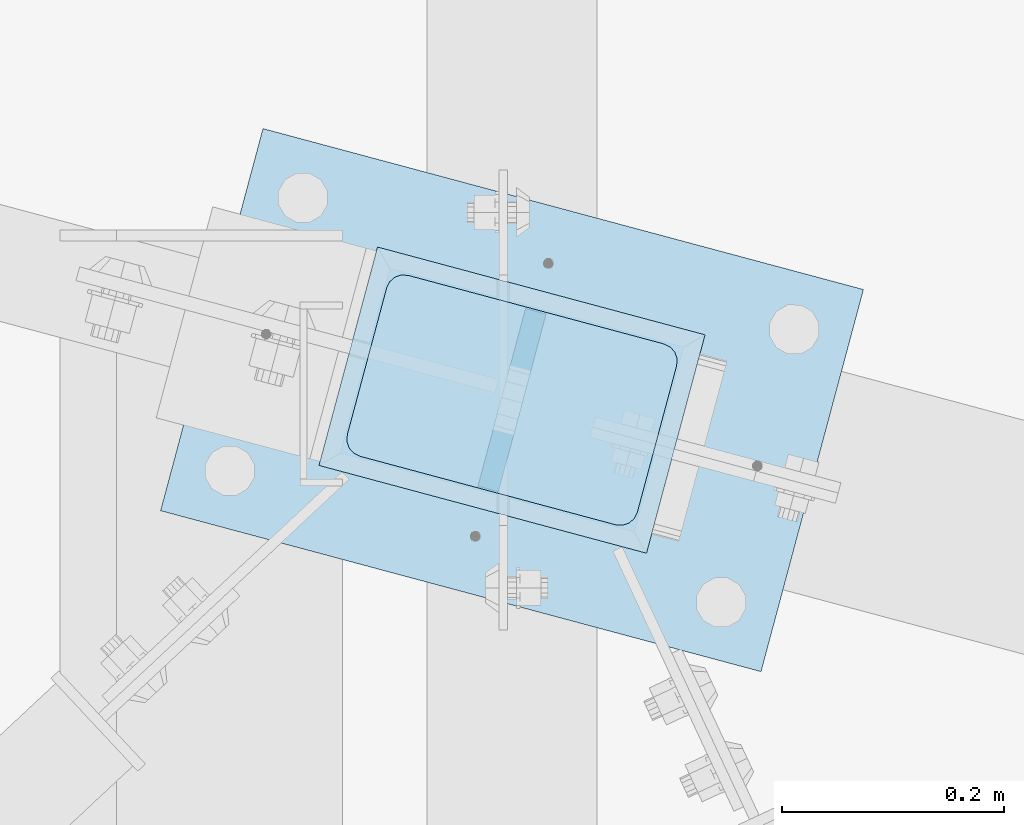
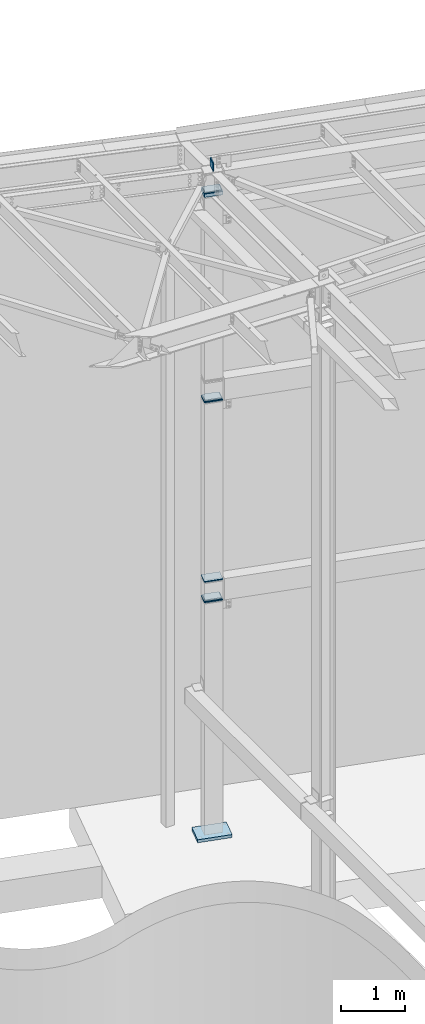
# One storey, part 1665 of 1763: 13 plates, 1 element without a shape of its own.
"""IFC2X3 building model written with IfcOpenShell, lengths in millimetres."""

import ifcopenshell
import ifcopenshell.guid

model = None  # the IFC model being written
_history = None  # IfcOwnerHistory: only IFC2X3 demands one
_inside = {}  # id of a spatial element -> (the spatial element, [elements in it])
_under = {}  # id of a project, library or spatial element -> (it, [spatial elements below it])
_declared = {}  # id of a project -> (the project, [libraries it declares])
_typed = {}  # id of a type object -> (the type object, [elements of that type])
_made_of = {}  # id of a material, layer set ... -> (it, [elements and type objects made of it])


def new_model(schema):
    """Start an empty IFC model of exactly this schema.

    Asked for "IFC4X3", IfcOpenShell would pick the latest addendum, in which some entities
    have other attributes; the version numbers below select the first issue.
    IFC2X3 requires an IfcOwnerHistory on every rooted entity: one is made here for all.
    """
    global model, _history
    if schema == "IFC4X3":
        model = ifcopenshell.file(schema_version=(4, 3, 0, 0))
    else:
        model = ifcopenshell.file(schema=schema)
    _inside.clear()
    _under.clear()
    _declared.clear()
    _typed.clear()
    _made_of.clear()
    _history = None
    if model.schema == "IFC2X3":
        org = make("IfcOrganization", Name="unknown")
        user = make(
            "IfcPersonAndOrganization",
            ThePerson=make("IfcPerson", FamilyName="unknown"),
            TheOrganization=org,
        )
        app = make(
            "IfcApplication",
            ApplicationDeveloper=org,
            Version="unknown",
            ApplicationFullName="unknown",
            ApplicationIdentifier="unknown",
        )
        _history = make(
            "IfcOwnerHistory",
            OwningUser=user,
            OwningApplication=app,
            ChangeAction="ADDED",
            CreationDate=0,
        )
    return model


def make(cls, **values):
    """One entity of the class cls with the attributes given. An attribute that is None is left unset."""
    return model.create_entity(
        cls, **{name: value for name, value in values.items() if value is not None}
    )


def rooted(cls, **values):
    """An entity with a GlobalId (a new one), such as an element, a storey or a relation."""
    return make(cls, GlobalId=ifcopenshell.guid.new(), OwnerHistory=_history, **values)


def si_unit(unit_type, name, prefix=None):
    """IfcSIUnit, for example si_unit("LENGTHUNIT", "METRE", prefix="MILLI")."""
    return make("IfcSIUnit", UnitType=unit_type, Prefix=prefix, Name=name)


def assignment(units):
    """IfcUnitAssignment: the units of a project."""
    return None if units is None else make("IfcUnitAssignment", Units=units)


def point(xyz):
    """IfcCartesianPoint."""
    return None if xyz is None else make("IfcCartesianPoint", Coordinates=xyz)


def direction(xyz):
    """IfcDirection."""
    return None if xyz is None else make("IfcDirection", DirectionRatios=xyz)


def frame(location, z_axis=None, x_axis=None):
    """IfcAxis2Placement3D, a coordinate frame: its origin and axes. An axis left out is left unset."""
    return make(
        "IfcAxis2Placement3D",
        Location=point(location),
        Axis=direction(z_axis),
        RefDirection=direction(x_axis),
    )


def origin_with_axes():
    """The frame at (0, 0, 0) with the z axis (0, 0, 1) and the x axis (1, 0, 0) written out."""
    return frame((0.0, 0.0, 0.0), z_axis=(0.0, 0.0, 1.0), x_axis=(1.0, 0.0, 0.0))


def place(relative_to, where):
    """IfcLocalPlacement: puts the frame where relative to a parent placement (None: the world)."""
    return make(
        "IfcLocalPlacement", PlacementRelTo=relative_to, RelativePlacement=where
    )


def context(
    kind, dimensions, precision=None, world=None, true_north=None, identifier=None
):
    """IfcGeometricRepresentationContext, for example the 3D "Model" context."""
    return make(
        "IfcGeometricRepresentationContext",
        ContextIdentifier=identifier,
        ContextType=kind,
        CoordinateSpaceDimension=dimensions,
        Precision=precision,
        WorldCoordinateSystem=world,
        TrueNorth=true_north,
    )


def subcontext(parent, identifier, kind, view, scale=None):
    """IfcGeometricRepresentationSubContext, for example "Body" below "Model"."""
    return make(
        "IfcGeometricRepresentationSubContext",
        ContextIdentifier=identifier,
        ContextType=kind,
        ParentContext=parent,
        TargetScale=scale,
        TargetView=view,
    )


def project(units=None, contexts=None):
    """IfcProject with its units and contexts."""
    return rooted(
        "IfcProject",
        Name="project",
        RepresentationContexts=contexts,
        UnitsInContext=assignment(units),
    )


def spatial(cls, under=None, at=None, **own):
    """A site, building, storey or space (cls), placed at a placement, below another one or the project."""
    s = rooted(cls, ObjectPlacement=at, **own)
    if under is not None:
        _under.setdefault(under.id(), (under, []))[1].append(s)
    return s


def faces_of(points, faces, orient=None, outer=None):
    """IfcFace entities. A face is a list of loops; a loop is a list of indices into points, from 0.

    orient and outer hold one flag for each loop. By default every Orientation is true, the
    first loop of a face is its IfcFaceOuterBound and the others are IfcFaceBound.
    """
    made = []
    for i, loops in enumerate(faces):
        bounds = []
        for j, loop in enumerate(loops):
            is_outer = j == 0 if outer is None else outer[i][j]
            bounds.append(
                make(
                    "IfcFaceOuterBound" if is_outer else "IfcFaceBound",
                    Bound=make("IfcPolyLoop", Polygon=[points[k] for k in loop]),
                    Orientation=True if orient is None else orient[i][j],
                )
            )
        made.append(make("IfcFace", Bounds=bounds))
    return made


def faceted_brep(points, faces, orient=None, outer=None, voids=None):
    """IfcFacetedBrep: a solid bounded by flat faces; with voids (closed shells), ...WithVoids."""
    shared = [point(p) for p in points]
    hull = make("IfcClosedShell", CfsFaces=faces_of(shared, faces, orient, outer))
    if voids is None:
        return make("IfcFacetedBrep", Outer=hull)
    return make(
        "IfcFacetedBrepWithVoids",
        Outer=hull,
        Voids=[
            make(cls, CfsFaces=faces_of(shared, fs, o, b)) for cls, fs, o, b in voids
        ],
    )


def shape(context_of_items, identifier, shape_type, items):
    """IfcShapeRepresentation: the items that make up one representation, for example the "Body"."""
    return make(
        "IfcShapeRepresentation",
        ContextOfItems=context_of_items,
        RepresentationIdentifier=identifier,
        RepresentationType=shape_type,
        Items=items,
    )


def material(Name=None, Category=None):
    """IfcMaterial."""
    return make("IfcMaterial", Name=Name, Category=Category)


def made_of(thing, what):
    """Note that an element or type object is made of a material, layer set ...; save() writes the relation."""
    if what is not None:
        _made_of.setdefault(what.id(), (what, []))[1].append(thing)
    return thing


def type_object(cls, material=None, **own):
    """A type object (cls), such as IfcWallType, which elements share."""
    return made_of(rooted(cls, **own), material)


def element(
    cls,
    number,
    at=None,
    inside=None,
    cuts=None,
    type_object=None,
    material=None,
    context=None,
    identifier="Body",
    shape_type=None,
    held_by="IfcProductDefinitionShape",
    body=None,
    shapes=None,
    **own,
):
    """One element of the class cls, such as IfcWall. Its Tag is "e" and its number.

    at: its placement. inside: the storey or other place that contains it. cuts: it is an
    opening in that element (IfcRelVoidsElement). A single representation is given by context,
    identifier, shape_type and body (its items); several are given by shapes. held_by: the class
    of the entity that holds the representations. save() writes the other relations.
    """
    e = rooted(cls, Tag="e%d" % number, ObjectPlacement=at, **own)
    if body is not None:
        shapes = [shape(context, identifier, shape_type, body)]
    if shapes is not None:
        e.Representation = make(held_by, Representations=shapes)
    if inside is not None:
        _inside.setdefault(inside.id(), (inside, []))[1].append(e)
    if cuts is not None:
        rooted(
            "IfcRelVoidsElement", RelatingBuildingElement=cuts, RelatedOpeningElement=e
        )
    if type_object is not None:
        _typed.setdefault(type_object.id(), (type_object, []))[1].append(e)
    return made_of(e, material)


def aggregate(whole, parts):
    """IfcRelAggregates: a whole, such as a stair, and the parts it consists of."""
    return rooted("IfcRelAggregates", RelatingObject=whole, RelatedObjects=parts)


def save(model, path):
    """Write the relations noted so far, then the file.

    IfcRelAggregates (storeys below a building ...), IfcRelContainedInSpatialStructure (elements
    in a storey), IfcRelDefinesByType, IfcRelAssociatesMaterial and IfcRelDeclares: one each for
    every whole, place, type object, material and project.
    """
    for whole, parts in _under.values():
        aggregate(whole, parts)
    for where, things in _inside.values():
        rooted(
            "IfcRelContainedInSpatialStructure",
            RelatedElements=things,
            RelatingStructure=where,
        )
    for kind, things in _typed.values():
        rooted("IfcRelDefinesByType", RelatedObjects=things, RelatingType=kind)
    for what, things in _made_of.values():
        rooted("IfcRelAssociatesMaterial", RelatedObjects=things, RelatingMaterial=what)
    for by, libraries in _declared.values():
        rooted("IfcRelDeclares", RelatingContext=by, RelatedDefinitions=libraries)
    model.write(path)


model = new_model("IFC2X3")

# Units and contexts
model_context = context("Model", 3, precision=1e-05, world=origin_with_axes())
body_context = subcontext(model_context, "Body", "Model", "MODEL_VIEW")
ifc_project = project(units=[si_unit("LENGTHUNIT", "METRE", prefix="MILLI"), si_unit("AREAUNIT", "SQUARE_METRE"), si_unit("VOLUMEUNIT", "CUBIC_METRE"), si_unit("MASSUNIT", "GRAM", prefix="KILO"), si_unit("TIMEUNIT", "SECOND"), si_unit("PLANEANGLEUNIT", "RADIAN"), si_unit("SOLIDANGLEUNIT", "STERADIAN"), si_unit("THERMODYNAMICTEMPERATUREUNIT", "DEGREE_CELSIUS"), si_unit("LUMINOUSINTENSITYUNIT", "LUMEN")], contexts=[model_context])

# Site, building, storey
site_placement = place(None, origin_with_axes())
site = spatial("IfcSite", under=ifc_project, at=site_placement, CompositionType="ELEMENT")
building_placement = place(site_placement, origin_with_axes())
building = spatial("IfcBuilding", under=site, at=building_placement, Name="Undefined", CompositionType="ELEMENT")
storey_placement = place(building_placement, origin_with_axes())
storey = spatial("IfcBuildingStorey", under=building, at=storey_placement, Name="Undefined", CompositionType="ELEMENT", Elevation=0.0)

# Assembly, plates
assembly_placement = place(storey_placement, origin_with_axes())
assembly = element("IfcElementAssembly", 1, at=assembly_placement, inside=storey, Name="COLUMN", AssemblyPlace="NOTDEFINED", PredefinedType="RIGID_FRAME")
ifc_material_1 = material(Name="STEEL/A36")
plate_type_1 = type_object("IfcPlateType", PredefinedType="NOTDEFINED")
plate_1_placement = place(assembly_placement, frame((-39780.8567256757, 66797.60536682, 8105.775), z_axis=(0.965913267114843, -0.258865912030785, 0.0), x_axis=(-0.258865912030778, -0.965913267114844, 3.00823476209188e-08)))
plate_1 = element("IfcPlate", 2, at=plate_1_placement, type_object=plate_type_1, material=ifc_material_1, Name="PLATE", context=body_context, shape_type="Brep", body=[
    faceted_brep([(-2.18278728425503e-11, -12.7000000000007, 15.875), (-1.67347025126219e-10, -12.7000000000007, 253.999999999985), (-1.67347025126219e-10, 12.7000000000007, 253.999999999985), (-2.18278728425503e-11, 12.7000000000007, 15.875), (1.20841242121242, -12.7000000000007, 260.075099488779), (1.20841242121242, 12.7000000000007, 260.075099488779), (4.649679848495, -12.7000000000007, 265.225320151323), (4.649679848495, 12.7000000000007, 265.225320151323), (9.79990051103232, -12.7000000000007, 268.666587578606), (9.79990051103232, 12.7000000000007, 268.666587578606), (15.8749999998181, -12.7000000000007, 269.874999999993), (15.8749999998181, 12.7000000000007, 269.874999999993), (152.400009155084, -12.7000000000007, 269.875000000073), (152.400009155084, 12.7000000000007, 269.875000000073), (158.475108643877, -12.7000000000007, 268.6665875787), (158.475108643877, 12.7000000000007, 268.6665875787), (163.625329306422, -12.7000000000007, 265.225320151425), (163.625329306422, 12.7000000000007, 265.225320151425), (167.066596733705, -12.7000000000007, 260.07509948888), (167.066596733705, 12.7000000000007, 260.07509948888), (168.275009155092, -12.7000000000007, 254.000000000087), (168.275009155092, 12.7000000000007, 254.000000000087), (168.275009155237, -12.7000000000007, 15.8750000001019), (168.275009155237, 12.7000000000007, 15.8750000001019), (167.066596733865, -12.7000000000007, 9.79990051130881), (167.066596733865, 12.7000000000007, 9.79990051130881), (163.625329306582, -12.7000000000007, 4.64967984876421), (163.625329306582, 12.7000000000007, 4.64967984876421), (158.475108644045, -12.7000000000007, 1.20841242148163), (158.475108644045, 12.7000000000007, 1.20841242148163), (152.400000000001, -12.6999998092651, 0.0), (152.400000000001, 12.6999998092651, 0.0), (15.8749999999854, -12.7000000000007, 0.0), (15.8749999999854, 12.7000000000007, 0.0), (9.79990051119239, -12.7000000000007, 1.20841242137976), (9.79990051119239, 12.7000000000007, 1.20841242137976), (4.64967984864779, -12.7000000000007, 4.64967984866234), (4.64967984864779, 12.7000000000007, 4.64967984866234), (1.20841242136521, -12.7000000000007, 9.79990051119967), (1.20841242136521, 12.7000000000007, 9.79990051119967)], [[[0, 1, 2, 3]], [[1, 4, 5, 2]], [[4, 6, 7, 5]], [[6, 8, 9, 7]], [[8, 10, 11, 9]], [[10, 12, 13, 11]], [[12, 14, 15, 13]], [[14, 16, 17, 15]], [[16, 18, 19, 17]], [[18, 20, 21, 19]], [[20, 22, 23, 21]], [[22, 24, 25, 23]], [[24, 26, 27, 25]], [[26, 28, 29, 27]], [[28, 30, 31, 29]], [[30, 32, 33, 31]], [[32, 34, 35, 33]], [[34, 36, 37, 35]], [[36, 38, 39, 37]], [[38, 0, 3, 39]], [[5, 7, 9, 11, 13, 15, 17, 19, 21, 23, 25, 27, 29, 31, 33, 35, 37, 39, 3, 2]], [[38, 36, 34, 32, 30, 28, 26, 24, 22, 20, 18, 16, 14, 12, 10, 8, 6, 4, 1, 0]]]),
])
plate_2_placement = place(assembly_placement, frame((-39780.856725713, 66797.60536683, 8064.5), z_axis=(0.965913267114843, -0.258865912030785, 0.0), x_axis=(-0.258865912030778, -0.965913267114844, 3.00823476209188e-08)))
plate_2 = element("IfcPlate", 3, at=plate_2_placement, type_object=plate_type_1, material=ifc_material_1, Name="PLATE", context=body_context, shape_type="Brep", body=[
    faceted_brep([(-2.18278728425503e-11, -12.7000000000007, 15.875), (-1.67347025126219e-10, -12.7000000000007, 253.999999999985), (-1.67347025126219e-10, 12.7000000000007, 253.999999999985), (-2.18278728425503e-11, 12.7000000000007, 15.875), (1.20841242121242, -12.7000000000007, 260.075099488779), (1.20841242121242, 12.7000000000007, 260.075099488779), (4.649679848495, -12.7000000000007, 265.225320151323), (4.649679848495, 12.7000000000007, 265.225320151323), (9.79990051103232, -12.7000000000007, 268.666587578606), (9.79990051103232, 12.7000000000007, 268.666587578606), (15.8749999998181, -12.7000000000007, 269.874999999993), (15.8749999998181, 12.7000000000007, 269.874999999993), (152.400009155084, -12.7000000000007, 269.875000000073), (152.400009155084, 12.7000000000007, 269.875000000073), (158.475108643877, -12.7000000000007, 268.6665875787), (158.475108643877, 12.7000000000007, 268.6665875787), (163.625329306422, -12.7000000000007, 265.225320151425), (163.625329306422, 12.7000000000007, 265.225320151425), (167.066596733705, -12.7000000000007, 260.07509948888), (167.066596733705, 12.7000000000007, 260.07509948888), (168.275009155092, -12.7000000000007, 254.000000000087), (168.275009155092, 12.7000000000007, 254.000000000087), (168.275009155237, -12.7000000000007, 15.8750000001019), (168.275009155237, 12.7000000000007, 15.8750000001019), (167.066596733865, -12.7000000000007, 9.79990051130881), (167.066596733865, 12.7000000000007, 9.79990051130881), (163.625329306582, -12.7000000000007, 4.64967984876421), (163.625329306582, 12.7000000000007, 4.64967984876421), (158.475108644045, -12.7000000000007, 1.20841242148163), (158.475108644045, 12.7000000000007, 1.20841242148163), (152.400000000001, -12.6999998092651, 0.0), (152.400000000001, 12.6999998092651, 0.0), (15.8749999999854, -12.7000000000007, 0.0), (15.8749999999854, 12.7000000000007, 0.0), (9.79990051119239, -12.7000000000007, 1.20841242137976), (9.79990051119239, 12.7000000000007, 1.20841242137976), (4.64967984864779, -12.7000000000007, 4.64967984866234), (4.64967984864779, 12.7000000000007, 4.64967984866234), (1.20841242136521, -12.7000000000007, 9.79990051119967), (1.20841242136521, 12.7000000000007, 9.79990051119967)], [[[0, 1, 2, 3]], [[1, 4, 5, 2]], [[4, 6, 7, 5]], [[6, 8, 9, 7]], [[8, 10, 11, 9]], [[10, 12, 13, 11]], [[12, 14, 15, 13]], [[14, 16, 17, 15]], [[16, 18, 19, 17]], [[18, 20, 21, 19]], [[20, 22, 23, 21]], [[22, 24, 25, 23]], [[24, 26, 27, 25]], [[26, 28, 29, 27]], [[28, 30, 31, 29]], [[30, 32, 33, 31]], [[32, 34, 35, 33]], [[34, 36, 37, 35]], [[36, 38, 39, 37]], [[38, 0, 3, 39]], [[5, 7, 9, 11, 13, 15, 17, 19, 21, 23, 25, 27, 29, 31, 33, 35, 37, 39, 3, 2]], [[38, 36, 34, 32, 30, 28, 26, 24, 22, 20, 18, 16, 14, 12, 10, 8, 6, 4, 1, 0]]]),
])
plate_3_placement = place(assembly_placement, frame((-39780.8472022852, 66797.6028150352, 4645.025), z_axis=(0.965913267114843, -0.258865912030785, 0.0), x_axis=(-0.258865912030778, -0.965913267114844, 3.00823476209188e-08)))
plate_3 = element("IfcPlate", 4, at=plate_3_placement, type_object=plate_type_1, material=ifc_material_1, Name="PLATE", context=body_context, shape_type="Brep", body=[
    faceted_brep([(-2.18278728425503e-11, -12.7000000000007, 15.875), (-1.67347025126219e-10, -12.7000000000007, 253.999999999985), (-1.67347025126219e-10, 12.7000000000007, 253.999999999985), (-2.18278728425503e-11, 12.7000000000007, 15.875), (1.20841242121242, -12.7000000000007, 260.075099488779), (1.20841242121242, 12.7000000000007, 260.075099488779), (4.649679848495, -12.7000000000007, 265.225320151323), (4.649679848495, 12.7000000000007, 265.225320151323), (9.79990051103232, -12.7000000000007, 268.666587578606), (9.79990051103232, 12.7000000000007, 268.666587578606), (15.8749999998181, -12.7000000000007, 269.874999999993), (15.8749999998181, 12.7000000000007, 269.874999999993), (152.400009155084, -12.7000000000007, 269.875000000073), (152.400009155084, 12.7000000000007, 269.875000000073), (158.475108643877, -12.7000000000007, 268.6665875787), (158.475108643877, 12.7000000000007, 268.6665875787), (163.625329306422, -12.7000000000007, 265.225320151425), (163.625329306422, 12.7000000000007, 265.225320151425), (167.066596733705, -12.7000000000007, 260.07509948888), (167.066596733705, 12.7000000000007, 260.07509948888), (168.275009155092, -12.7000000000007, 254.000000000087), (168.275009155092, 12.7000000000007, 254.000000000087), (168.275009155237, -12.7000000000007, 15.8750000001019), (168.275009155237, 12.7000000000007, 15.8750000001019), (167.066596733865, -12.7000000000007, 9.79990051130881), (167.066596733865, 12.7000000000007, 9.79990051130881), (163.625329306582, -12.7000000000007, 4.64967984876421), (163.625329306582, 12.7000000000007, 4.64967984876421), (158.475108644045, -12.7000000000007, 1.20841242148163), (158.475108644045, 12.7000000000007, 1.20841242148163), (152.400000000001, -12.6999998092651, 0.0), (152.400000000001, 12.6999998092651, 0.0), (15.8749999999854, -12.7000000000007, 0.0), (15.8749999999854, 12.7000000000007, 0.0), (9.79990051119239, -12.7000000000007, 1.20841242137976), (9.79990051119239, 12.7000000000007, 1.20841242137976), (4.64967984864779, -12.7000000000007, 4.64967984866234), (4.64967984864779, 12.7000000000007, 4.64967984866234), (1.20841242136521, -12.7000000000007, 9.79990051119967), (1.20841242136521, 12.7000000000007, 9.79990051119967)], [[[0, 1, 2, 3]], [[1, 4, 5, 2]], [[4, 6, 7, 5]], [[6, 8, 9, 7]], [[8, 10, 11, 9]], [[10, 12, 13, 11]], [[12, 14, 15, 13]], [[14, 16, 17, 15]], [[16, 18, 19, 17]], [[18, 20, 21, 19]], [[20, 22, 23, 21]], [[22, 24, 25, 23]], [[24, 26, 27, 25]], [[26, 28, 29, 27]], [[28, 30, 31, 29]], [[30, 32, 33, 31]], [[32, 34, 35, 33]], [[34, 36, 37, 35]], [[36, 38, 39, 37]], [[38, 0, 3, 39]], [[5, 7, 9, 11, 13, 15, 17, 19, 21, 23, 25, 27, 29, 31, 33, 35, 37, 39, 3, 2]], [[38, 36, 34, 32, 30, 28, 26, 24, 22, 20, 18, 16, 14, 12, 10, 8, 6, 4, 1, 0]]]),
])
plate_4_placement = place(assembly_placement, frame((-39780.8472022484, 66797.6028150254, 4295.775), z_axis=(0.965913267114843, -0.258865912030785, 0.0), x_axis=(-0.258865912030778, -0.965913267114844, 3.00823476209188e-08)))
plate_4 = element("IfcPlate", 5, at=plate_4_placement, type_object=plate_type_1, material=ifc_material_1, Name="PLATE", context=body_context, shape_type="Brep", body=[
    faceted_brep([(-2.18278728425503e-11, -12.7000000000007, 15.875), (-1.67347025126219e-10, -12.7000000000007, 253.999999999985), (-1.67347025126219e-10, 12.7000000000007, 253.999999999985), (-2.18278728425503e-11, 12.7000000000007, 15.875), (1.20841242121242, -12.7000000000007, 260.075099488779), (1.20841242121242, 12.7000000000007, 260.075099488779), (4.649679848495, -12.7000000000007, 265.225320151323), (4.649679848495, 12.7000000000007, 265.225320151323), (9.79990051103232, -12.7000000000007, 268.666587578606), (9.79990051103232, 12.7000000000007, 268.666587578606), (15.8749999998181, -12.7000000000007, 269.874999999993), (15.8749999998181, 12.7000000000007, 269.874999999993), (152.400009155084, -12.7000000000007, 269.875000000073), (152.400009155084, 12.7000000000007, 269.875000000073), (158.475108643877, -12.7000000000007, 268.6665875787), (158.475108643877, 12.7000000000007, 268.6665875787), (163.625329306422, -12.7000000000007, 265.225320151425), (163.625329306422, 12.7000000000007, 265.225320151425), (167.066596733705, -12.7000000000007, 260.07509948888), (167.066596733705, 12.7000000000007, 260.07509948888), (168.275009155092, -12.7000000000007, 254.000000000087), (168.275009155092, 12.7000000000007, 254.000000000087), (168.275009155237, -12.7000000000007, 15.8750000001019), (168.275009155237, 12.7000000000007, 15.8750000001019), (167.066596733865, -12.7000000000007, 9.79990051130881), (167.066596733865, 12.7000000000007, 9.79990051130881), (163.625329306582, -12.7000000000007, 4.64967984876421), (163.625329306582, 12.7000000000007, 4.64967984876421), (158.475108644045, -12.7000000000007, 1.20841242148163), (158.475108644045, 12.7000000000007, 1.20841242148163), (152.400000000001, -12.6999998092651, 0.0), (152.400000000001, 12.6999998092651, 0.0), (15.8749999999854, -12.7000000000007, 0.0), (15.8749999999854, 12.7000000000007, 0.0), (9.79990051119239, -12.7000000000007, 1.20841242137976), (9.79990051119239, 12.7000000000007, 1.20841242137976), (4.64967984864779, -12.7000000000007, 4.64967984866234), (4.64967984864779, 12.7000000000007, 4.64967984866234), (1.20841242136521, -12.7000000000007, 9.79990051119967), (1.20841242136521, 12.7000000000007, 9.79990051119967)], [[[0, 1, 2, 3]], [[1, 4, 5, 2]], [[4, 6, 7, 5]], [[6, 8, 9, 7]], [[8, 10, 11, 9]], [[10, 12, 13, 11]], [[12, 14, 15, 13]], [[14, 16, 17, 15]], [[16, 18, 19, 17]], [[18, 20, 21, 19]], [[20, 22, 23, 21]], [[22, 24, 25, 23]], [[24, 26, 27, 25]], [[26, 28, 29, 27]], [[28, 30, 31, 29]], [[30, 32, 33, 31]], [[32, 34, 35, 33]], [[34, 36, 37, 35]], [[36, 38, 39, 37]], [[38, 0, 3, 39]], [[5, 7, 9, 11, 13, 15, 17, 19, 21, 23, 25, 27, 29, 31, 33, 35, 37, 39, 3, 2]], [[38, 36, 34, 32, 30, 28, 26, 24, 22, 20, 18, 16, 14, 12, 10, 8, 6, 4, 1, 0]]]),
])
plate_5_placement = place(assembly_placement, frame((-39780.8472022858, 66797.6028150354, 4254.5), z_axis=(0.965913267114843, -0.258865912030785, 0.0), x_axis=(-0.258865912030778, -0.965913267114844, 3.00823476209188e-08)))
plate_5 = element("IfcPlate", 6, at=plate_5_placement, type_object=plate_type_1, material=ifc_material_1, Name="PLATE", context=body_context, shape_type="Brep", body=[
    faceted_brep([(-2.18278728425503e-11, -12.7000000000007, 15.875), (-1.67347025126219e-10, -12.7000000000007, 253.999999999985), (-1.67347025126219e-10, 12.7000000000007, 253.999999999985), (-2.18278728425503e-11, 12.7000000000007, 15.875), (1.20841242121242, -12.7000000000007, 260.075099488779), (1.20841242121242, 12.7000000000007, 260.075099488779), (4.649679848495, -12.7000000000007, 265.225320151323), (4.649679848495, 12.7000000000007, 265.225320151323), (9.79990051103232, -12.7000000000007, 268.666587578606), (9.79990051103232, 12.7000000000007, 268.666587578606), (15.8749999998181, -12.7000000000007, 269.874999999993), (15.8749999998181, 12.7000000000007, 269.874999999993), (152.400009155084, -12.7000000000007, 269.875000000073), (152.400009155084, 12.7000000000007, 269.875000000073), (158.475108643877, -12.7000000000007, 268.6665875787), (158.475108643877, 12.7000000000007, 268.6665875787), (163.625329306422, -12.7000000000007, 265.225320151425), (163.625329306422, 12.7000000000007, 265.225320151425), (167.066596733705, -12.7000000000007, 260.07509948888), (167.066596733705, 12.7000000000007, 260.07509948888), (168.275009155092, -12.7000000000007, 254.000000000087), (168.275009155092, 12.7000000000007, 254.000000000087), (168.275009155237, -12.7000000000007, 15.8750000001019), (168.275009155237, 12.7000000000007, 15.8750000001019), (167.066596733865, -12.7000000000007, 9.79990051130881), (167.066596733865, 12.7000000000007, 9.79990051130881), (163.625329306582, -12.7000000000007, 4.64967984876421), (163.625329306582, 12.7000000000007, 4.64967984876421), (158.475108644045, -12.7000000000007, 1.20841242148163), (158.475108644045, 12.7000000000007, 1.20841242148163), (152.400000000001, -12.6999998092651, 0.0), (152.400000000001, 12.6999998092651, 0.0), (15.8749999999854, -12.7000000000007, 0.0), (15.8749999999854, 12.7000000000007, 0.0), (9.79990051119239, -12.7000000000007, 1.20841242137976), (9.79990051119239, 12.7000000000007, 1.20841242137976), (4.64967984864779, -12.7000000000007, 4.64967984866234), (4.64967984864779, 12.7000000000007, 4.64967984866234), (1.20841242136521, -12.7000000000007, 9.79990051119967), (1.20841242136521, 12.7000000000007, 9.79990051119967)], [[[0, 1, 2, 3]], [[1, 4, 5, 2]], [[4, 6, 7, 5]], [[6, 8, 9, 7]], [[8, 10, 11, 9]], [[10, 12, 13, 11]], [[12, 14, 15, 13]], [[14, 16, 17, 15]], [[16, 18, 19, 17]], [[18, 20, 21, 19]], [[20, 22, 23, 21]], [[22, 24, 25, 23]], [[24, 26, 27, 25]], [[26, 28, 29, 27]], [[28, 30, 31, 29]], [[30, 32, 33, 31]], [[32, 34, 35, 33]], [[34, 36, 37, 35]], [[36, 38, 39, 37]], [[38, 0, 3, 39]], [[5, 7, 9, 11, 13, 15, 17, 19, 21, 23, 25, 27, 29, 31, 33, 35, 37, 39, 3, 2]], [[38, 36, 34, 32, 30, 28, 26, 24, 22, 20, 18, 16, 14, 12, 10, 8, 6, 4, 1, 0]]]),
])
plate_type_2 = type_object("IfcPlateType", PredefinedType="NOTDEFINED")
plate_6_placement = place(assembly_placement, frame((-39780.8472031509, 66797.602812108, 11985.625), z_axis=(0.965913267114843, -0.258865912030785, 0.0), x_axis=(-0.258865912030778, -0.965913267114844, 3.00823476209188e-08)))
plate_6 = element("IfcPlate", 7, at=plate_6_placement, type_object=plate_type_2, material=ifc_material_1, Name="PLATE", context=body_context, shape_type="Brep", body=[
    faceted_brep([(7.27595761418343e-11, -9.52499999999964, 15.8750000001601), (1.13504938781261e-09, -9.52499999999964, 254.000000000065), (1.13504938781261e-09, 9.52499999999964, 254.000000000065), (7.27595761418343e-11, 9.52499999999964, 15.8750000001601), (1.20841242253664, -9.52499999999964, 260.075099488837), (1.20841242253664, 9.52499999999964, 260.075099488837), (4.64967984981922, -9.52499999999964, 265.225320151352), (4.64967984981922, 9.52499999999964, 265.225320151352), (9.79990051234927, -9.52499999999964, 268.666587578613), (9.79990051234927, 9.52499999999964, 268.666587578613), (15.8750000011278, -9.52499999999964, 269.874999999993), (15.8750000011278, 9.52499999999964, 269.874999999993), (152.400009155099, -9.52499999999964, 269.87500000008), (152.400009155099, 9.52499999999964, 269.87500000008), (158.475108643885, -9.52499999999964, 268.6665875787), (158.475108643885, 9.52499999999964, 268.6665875787), (163.625329306429, -9.52499999999964, 265.225320151425), (163.625329306429, 9.52499999999964, 265.225320151425), (167.066596733726, -9.52499999999964, 260.07509948888), (167.066596733726, 9.52499999999964, 260.07509948888), (168.275009155106, -9.52499999999964, 254.000000000087), (168.275009155106, 9.52499999999964, 254.000000000087), (168.275009155259, -9.52499999999964, 15.8750000008658), (168.275009155259, 9.52499999999964, 15.8750000008658), (167.066596733886, -9.52499999999964, 9.79990051209461), (167.066596733886, 9.52499999999964, 9.79990051209461), (163.625329306633, -9.52499999999964, 4.64967984955729), (163.625329306633, 9.52499999999964, 4.64967984955729), (158.475108644117, -9.52499999999964, 1.20841242226743), (158.475108644117, 9.52499999999964, 1.20841242226743), (152.400009155353, -9.52499999999964, 8.58562998473644e-10), (152.400009155353, 9.52499999999964, 8.58562998473644e-10), (15.8750000001673, -9.52499999999964, 8.73114913702011e-11), (15.8750000001673, 9.52499999999964, 8.73114913702011e-11), (9.79990051132336, -9.52499999999964, 1.20841242144525), (9.79990051132336, 9.52499999999964, 1.20841242144525), (4.64967984874238, -9.52499999999964, 4.64967984874238), (4.64967984874238, 9.52499999999964, 4.64967984874238), (1.20841242144525, -9.52499999999964, 9.79990051132336), (1.20841242144525, 9.52499999999964, 9.79990051132336)], [[[0, 1, 2, 3]], [[1, 4, 5, 2]], [[4, 6, 7, 5]], [[6, 8, 9, 7]], [[8, 10, 11, 9]], [[10, 12, 13, 11]], [[12, 14, 15, 13]], [[14, 16, 17, 15]], [[16, 18, 19, 17]], [[18, 20, 21, 19]], [[20, 22, 23, 21]], [[22, 24, 25, 23]], [[24, 26, 27, 25]], [[26, 28, 29, 27]], [[28, 30, 31, 29]], [[30, 32, 33, 31]], [[32, 34, 35, 33]], [[34, 36, 37, 35]], [[36, 38, 39, 37]], [[38, 0, 3, 39]], [[5, 7, 9, 11, 13, 15, 17, 19, 21, 23, 25, 27, 29, 31, 33, 35, 37, 39, 3, 2]], [[38, 36, 34, 32, 30, 28, 26, 24, 22, 20, 18, 16, 14, 12, 10, 8, 6, 4, 1, 0]]]),
])
plate_7_placement = place(assembly_placement, frame((-39780.8472031329, 66797.602812104, 12068.175), z_axis=(0.965913267114843, -0.258865912030785, 0.0), x_axis=(-0.258865912030778, -0.965913267114844, 3.00823476209188e-08)))
plate_7 = element("IfcPlate", 8, at=plate_7_placement, type_object=plate_type_2, material=ifc_material_1, Name="PLATE", context=body_context, shape_type="Brep", body=[
    faceted_brep([(7.27595761418343e-11, -9.52499999999964, 15.8750000001601), (1.13504938781261e-09, -9.52499999999964, 254.000000000065), (1.13504938781261e-09, 9.52499999999964, 254.000000000065), (7.27595761418343e-11, 9.52499999999964, 15.8750000001601), (1.20841242253664, -9.52499999999964, 260.075099488837), (1.20841242253664, 9.52499999999964, 260.075099488837), (4.64967984981922, -9.52499999999964, 265.225320151352), (4.64967984981922, 9.52499999999964, 265.225320151352), (9.79990051234927, -9.52499999999964, 268.666587578613), (9.79990051234927, 9.52499999999964, 268.666587578613), (15.8750000011278, -9.52499999999964, 269.874999999993), (15.8750000011278, 9.52499999999964, 269.874999999993), (152.400009155099, -9.52499999999964, 269.87500000008), (152.400009155099, 9.52499999999964, 269.87500000008), (158.475108643885, -9.52499999999964, 268.6665875787), (158.475108643885, 9.52499999999964, 268.6665875787), (163.625329306429, -9.52499999999964, 265.225320151425), (163.625329306429, 9.52499999999964, 265.225320151425), (167.066596733726, -9.52499999999964, 260.07509948888), (167.066596733726, 9.52499999999964, 260.07509948888), (168.275009155106, -9.52499999999964, 254.000000000087), (168.275009155106, 9.52499999999964, 254.000000000087), (168.275009155259, -9.52499999999964, 15.8750000008658), (168.275009155259, 9.52499999999964, 15.8750000008658), (167.066596733886, -9.52499999999964, 9.79990051209461), (167.066596733886, 9.52499999999964, 9.79990051209461), (163.625329306633, -9.52499999999964, 4.64967984955729), (163.625329306633, 9.52499999999964, 4.64967984955729), (158.475108644117, -9.52499999999964, 1.20841242226743), (158.475108644117, 9.52499999999964, 1.20841242226743), (152.400009155353, -9.52499999999964, 8.58562998473644e-10), (152.400009155353, 9.52499999999964, 8.58562998473644e-10), (15.8750000001673, -9.52499999999964, 8.73114913702011e-11), (15.8750000001673, 9.52499999999964, 8.73114913702011e-11), (9.79990051132336, -9.52499999999964, 1.20841242144525), (9.79990051132336, 9.52499999999964, 1.20841242144525), (4.64967984874238, -9.52499999999964, 4.64967984874238), (4.64967984874238, 9.52499999999964, 4.64967984874238), (1.20841242144525, -9.52499999999964, 9.79990051132336), (1.20841242144525, 9.52499999999964, 9.79990051132336)], [[[0, 1, 2, 3]], [[1, 4, 5, 2]], [[4, 6, 7, 5]], [[6, 8, 9, 7]], [[8, 10, 11, 9]], [[10, 12, 13, 11]], [[12, 14, 15, 13]], [[14, 16, 17, 15]], [[16, 18, 19, 17]], [[18, 20, 21, 19]], [[20, 22, 23, 21]], [[22, 24, 25, 23]], [[24, 26, 27, 25]], [[26, 28, 29, 27]], [[28, 30, 31, 29]], [[30, 32, 33, 31]], [[32, 34, 35, 33]], [[34, 36, 37, 35]], [[36, 38, 39, 37]], [[38, 0, 3, 39]], [[5, 7, 9, 11, 13, 15, 17, 19, 21, 23, 25, 27, 29, 31, 33, 35, 37, 39, 3, 2]], [[38, 36, 34, 32, 30, 28, 26, 24, 22, 20, 18, 16, 14, 12, 10, 8, 6, 4, 1, 0]]]),
])
ifc_material_2 = material(Name="STEEL/A572-50")
plate_type_3 = type_object("IfcPlateType", PredefinedType="NOTDEFINED")
plate_8_placement = place(assembly_placement, frame((-39793.1940109033, 66818.9905198919, 8085.1375), z_axis=(0.965913267114843, -0.258865912030785, 0.0), x_axis=(-0.258865912030778, -0.965913267114844, 3.00823476209188e-08)))
plate_8 = element("IfcPlate", 9, at=plate_8_placement, type_object=plate_type_3, material=ifc_material_2, Name="PLATE", context=body_context, shape_type="Brep", body=[
    faceted_brep([(-7.27595761418343e-12, -7.9375, 0.0), (-1.96450855582952e-10, -7.9375, 304.799987792954), (-1.96450855582952e-10, 7.9375, 304.799987792954), (-7.27595761418343e-12, 7.9375, 0.0), (203.199996948031, -7.9375, 304.799987793078), (203.199996948031, 7.9375, 304.799987793078), (203.199996948228, -7.9375, 1.30967237055302e-10), (203.199996948228, 7.9375, 1.30967237055302e-10)], [[[0, 1, 2, 3]], [[1, 4, 5, 2]], [[4, 6, 7, 5]], [[6, 0, 3, 7]], [[5, 7, 3, 2]], [[6, 4, 1, 0]]]),
])
plate_9_placement = place(assembly_placement, frame((-39793.1844874755, 66818.9879680971, 4665.6625), z_axis=(0.965913267114843, -0.258865912030785, 0.0), x_axis=(-0.258865912030778, -0.965913267114844, 3.00823476209188e-08)))
plate_9 = element("IfcPlate", 10, at=plate_9_placement, type_object=plate_type_3, material=ifc_material_2, Name="PLATE", context=body_context, shape_type="Brep", body=[
    faceted_brep([(-7.27595761418343e-12, -7.9375, 0.0), (-1.96450855582952e-10, -7.9375, 304.799987792954), (-1.96450855582952e-10, 7.9375, 304.799987792954), (-7.27595761418343e-12, 7.9375, 0.0), (203.199996948031, -7.9375, 304.799987793078), (203.199996948031, 7.9375, 304.799987793078), (203.199996948228, -7.9375, 1.30967237055302e-10), (203.199996948228, 7.9375, 1.30967237055302e-10)], [[[0, 1, 2, 3]], [[1, 4, 5, 2]], [[4, 6, 7, 5]], [[6, 0, 3, 7]], [[5, 7, 3, 2]], [[6, 4, 1, 0]]]),
])
plate_10_placement = place(assembly_placement, frame((-39793.1844874761, 66818.9879680972, 4275.1375), z_axis=(0.965913267114843, -0.258865912030785, 0.0), x_axis=(-0.258865912030778, -0.965913267114844, 3.00823476209188e-08)))
plate_10 = element("IfcPlate", 11, at=plate_10_placement, type_object=plate_type_3, material=ifc_material_2, Name="PLATE", context=body_context, shape_type="Brep", body=[
    faceted_brep([(-7.27595761418343e-12, -7.9375, 0.0), (-1.96450855582952e-10, -7.9375, 304.799987792954), (-1.96450855582952e-10, 7.9375, 304.799987792954), (-7.27595761418343e-12, 7.9375, 0.0), (203.199996948031, -7.9375, 304.799987793078), (203.199996948031, 7.9375, 304.799987793078), (203.199996948228, -7.9375, 1.30967237055302e-10), (203.199996948228, 7.9375, 1.30967237055302e-10)], [[[0, 1, 2, 3]], [[1, 4, 5, 2]], [[4, 6, 7, 5]], [[6, 0, 3, 7]], [[5, 7, 3, 2]], [[6, 4, 1, 0]]]),
])
plate_type_4 = type_object("IfcPlateType", PredefinedType="NOTDEFINED")
plate_11_placement = place(assembly_placement, frame((-39650.8921786426, 66761.2289433038, 12611.0999938965), z_axis=(0.0, 0.0, -1.0), x_axis=(-0.258911937048181, -0.965900931179776, 0.0)))
plate_11 = element("IfcPlate", 12, at=plate_11_placement, type_object=plate_type_4, material=ifc_material_2, Name="PLATE", context=body_context, shape_type="Brep", body=[
    faceted_brep([(7.27595761418343e-12, 9.52500000000146, 155.574990844727), (-1.45519152283669e-11, 7.27595761418343e-12, 165.099990844727), (165.288833618244, 2.18278728425503e-10, 165.099990844727), (165.288833618273, 9.52500000021973, 155.574990844727), (-3.63797880709171e-11, -9.5249999999869, 155.574990844727), (165.288833618222, -9.5249999997759, 155.574990844727), (0.0, 9.52500000000146, 0.0), (0.0, -9.52500000000146, 0.0), (165.288833618222, -9.5249999997759, 0.0), (165.288833618273, 9.52500000021973, 0.0)], [[[0, 1, 2, 3]], [[1, 4, 5, 2]], [[6, 7, 4, 1, 0]], [[5, 8, 9, 3, 2]], [[8, 7, 6, 9]], [[9, 6, 0, 3]], [[7, 8, 5, 4]]]),
])
plate_type_5 = type_object("IfcPlateType", PredefinedType="NOTDEFINED")
plate_12_placement = place(assembly_placement, frame((-39793.194023473, 66818.9905201003, 12026.9), z_axis=(0.965913267114843, -0.258865912030785, 0.0), x_axis=(-0.258865912030778, -0.965913267114844, 3.00823476209188e-08)))
plate_12 = element("IfcPlate", 13, at=plate_12_placement, type_object=plate_type_5, material=ifc_material_2, Name="PLATE", context=body_context, shape_type="Brep", body=[
    faceted_brep([(-4.54747350886464e-13, -31.7499999999964, 0.0), (1.94268068298697e-09, -31.75, 304.799987793522), (1.94268068298697e-09, 31.75, 304.799987793522), (-5.91171556152403e-12, 31.7499999999891, 0.0), (203.199996948744, -31.75, 304.79998779326), (203.199996948744, 31.75, 304.79998779326), (203.199996946802, -31.75, -2.69210431724787e-10), (203.199996946802, 31.75, -2.69210431724787e-10)], [[[0, 1, 2, 3]], [[1, 4, 5, 2]], [[4, 6, 7, 5]], [[6, 0, 3, 7]], [[5, 7, 3, 2]], [[6, 4, 1, 0]]]),
])
ifc_material_3 = material(Name="STEEL/A572-GR.50")
plate_type_6 = type_object("IfcPlateType", PredefinedType="NOTDEFINED")
plate_13_placement = place(assembly_placement, frame((-39988.1921434054, 66581.9903270341, -200.025000000003), z_axis=(0.25886591203079, 0.965913267114842, 0.0), x_axis=(0.965913267114843, -0.258865912030785, 0.0)))
plate_13 = element("IfcPlate", 14, at=plate_13_placement, type_object=plate_type_6, material=ifc_material_3, Name="PLATE", context=body_context, shape_type="Brep", body=[
    faceted_brep([(0.0, -28.575, 0.0), (-2.18278728425503e-10, -28.575, 355.600006103494), (-2.18278728425503e-10, 28.575, 355.600006103494), (0.0, 28.575, 0.0), (558.799987792721, -28.575, 355.60000610385), (558.799987792721, 28.575, 355.60000610385), (558.79998779294, -28.575, 3.49245965480804e-10), (558.79998779294, 28.575, 3.49245965480804e-10)], [[[0, 1, 2, 3]], [[1, 4, 5, 2]], [[4, 6, 7, 5]], [[6, 0, 3, 7]], [[5, 7, 3, 2]], [[6, 4, 1, 0]]]),
])
aggregate(assembly, [plate_1, plate_2, plate_8, plate_3, plate_9, plate_4, plate_5, plate_10, plate_11, plate_6, plate_7, plate_12, plate_13])

save(model, "model.ifc")
